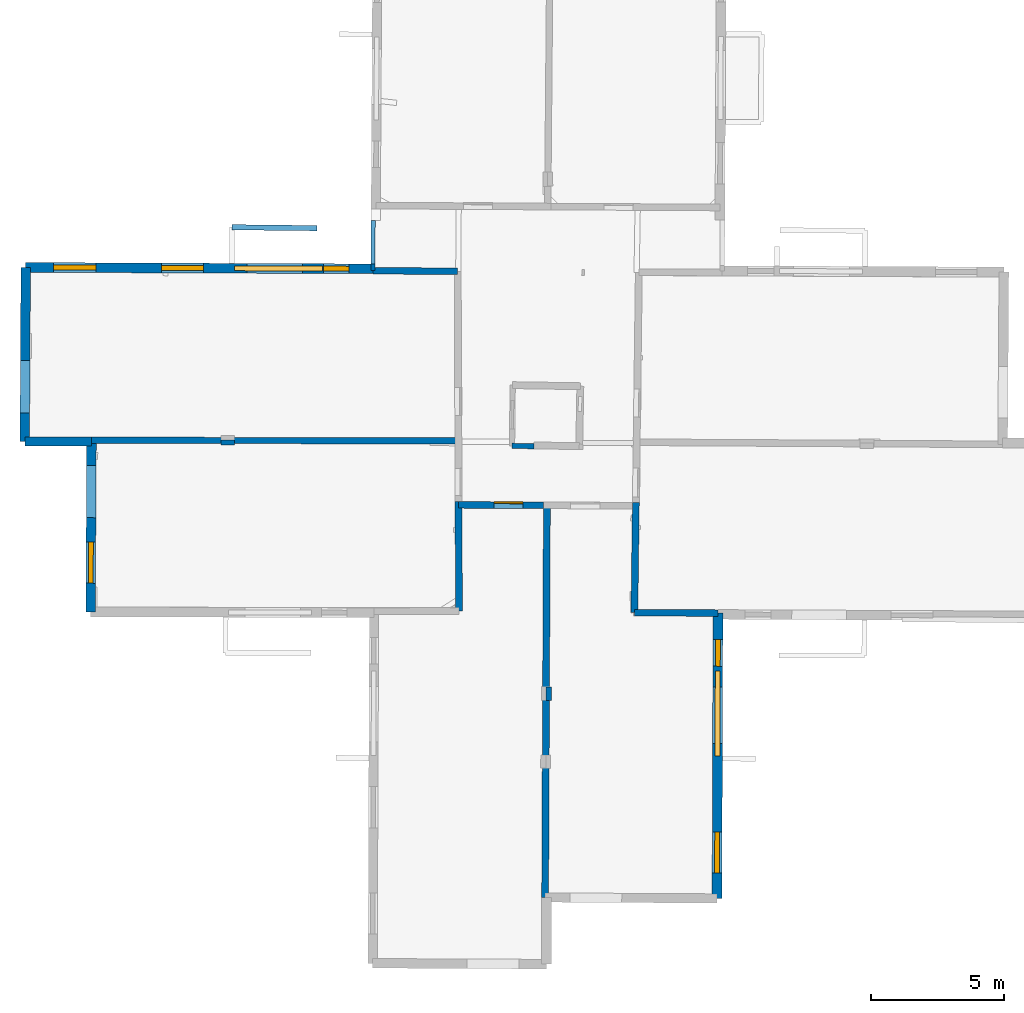
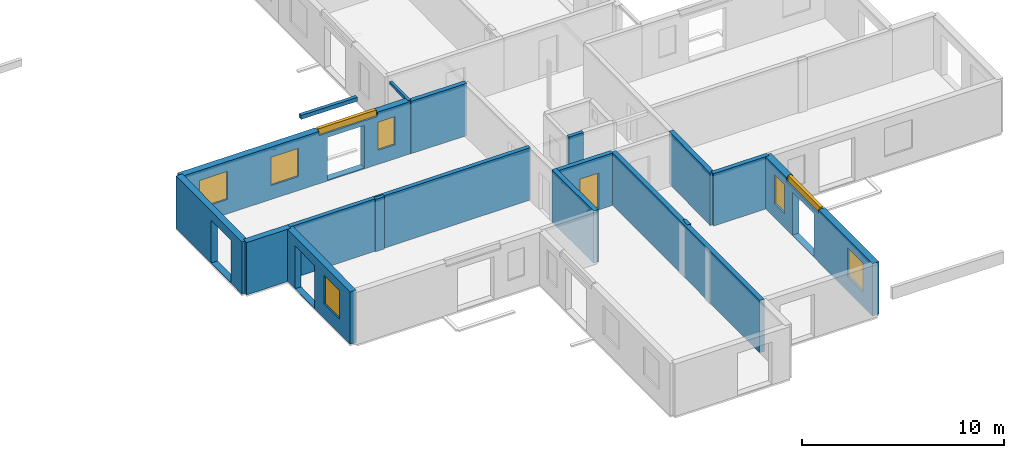
# One storey, part 4 of 17: 17 walls, 8 windows, 1 door, 14 openings.
"""IFC2X3 building model written with IfcOpenShell, lengths in metres."""

from ifc_helpers import new_model, entity, si_unit, converted_unit, derived_unit, direction, frame, frame_2d, origin, origin_2d_with_axis, place, context, subcontext, project, spatial, polyline, rectangle, outline, extrude, source, transform, mapped, material, layer, layer_set, layer_usage, type_object, type_shapes, element, fill, save


model = new_model("IFC2X3")

# Units and contexts
model_context = context("Model", 3, precision=1e-05, world=origin(), true_north=direction((0.0, 1.0)))
body_context = subcontext(model_context, "Body", "Model", "MODEL_VIEW")
ifc_project = project(units=[si_unit("LENGTHUNIT", "METRE"), si_unit("AREAUNIT", "SQUARE_METRE"), si_unit("VOLUMEUNIT", "CUBIC_METRE"), converted_unit("PLANEANGLEUNIT", "DEGREE", entity("IfcRatioMeasure", 0.0174532925199433), si_unit("PLANEANGLEUNIT", "RADIAN"), dimensions=[0, 0, 0, 0, 0, 0, 0]), si_unit("MASSUNIT", "GRAM", prefix="KILO"), derived_unit("MASSDENSITYUNIT", [(si_unit("MASSUNIT", "GRAM", prefix="KILO"), 1), (si_unit("LENGTHUNIT", "METRE"), -3)]), derived_unit("MOMENTOFINERTIAUNIT", [(si_unit("LENGTHUNIT", "METRE"), 4)]), si_unit("TIMEUNIT", "SECOND"), si_unit("FREQUENCYUNIT", "HERTZ"), si_unit("THERMODYNAMICTEMPERATUREUNIT", "DEGREE_CELSIUS"), derived_unit("THERMALTRANSMITTANCEUNIT", [(si_unit("MASSUNIT", "GRAM", prefix="KILO"), 1), (si_unit("THERMODYNAMICTEMPERATUREUNIT", "KELVIN"), -1), (si_unit("TIMEUNIT", "SECOND"), -3)]), derived_unit("VOLUMETRICFLOWRATEUNIT", [(si_unit("LENGTHUNIT", "METRE"), 3), (si_unit("TIMEUNIT", "SECOND"), -1)]), si_unit("ELECTRICCURRENTUNIT", "AMPERE"), si_unit("ELECTRICVOLTAGEUNIT", "VOLT"), si_unit("POWERUNIT", "WATT"), si_unit("FORCEUNIT", "NEWTON", prefix="KILO"), si_unit("ILLUMINANCEUNIT", "LUX"), si_unit("LUMINOUSFLUXUNIT", "LUMEN"), si_unit("LUMINOUSINTENSITYUNIT", "CANDELA"), derived_unit("USERDEFINED", [(si_unit("MASSUNIT", "GRAM", prefix="KILO"), -1), (si_unit("LENGTHUNIT", "METRE"), -2), (si_unit("TIMEUNIT", "SECOND"), 3), (si_unit("LUMINOUSFLUXUNIT", "LUMEN"), 1)]), derived_unit("LINEARVELOCITYUNIT", [(si_unit("LENGTHUNIT", "METRE"), 1), (si_unit("TIMEUNIT", "SECOND"), -1)]), si_unit("PRESSUREUNIT", "PASCAL"), derived_unit("USERDEFINED", [(si_unit("LENGTHUNIT", "METRE"), -2), (si_unit("MASSUNIT", "GRAM", prefix="KILO"), 1), (si_unit("TIMEUNIT", "SECOND"), -2)]), derived_unit("LINEARFORCEUNIT", [(si_unit("MASSUNIT", "GRAM", prefix="KILO"), 1), (si_unit("LENGTHUNIT", "METRE"), 1), (si_unit("TIMEUNIT", "SECOND"), -2), (si_unit("LENGTHUNIT", "METRE"), -1)]), derived_unit("PLANARFORCEUNIT", [(si_unit("MASSUNIT", "GRAM", prefix="KILO"), 1), (si_unit("LENGTHUNIT", "METRE"), 1), (si_unit("TIMEUNIT", "SECOND"), -2), (si_unit("LENGTHUNIT", "METRE"), -2)])], contexts=[model_context])

# Site, building, storey
placement_1 = place(None, origin())
site = spatial("IfcSite", under=ifc_project, at=placement_1, CompositionType="ELEMENT")
building = spatial("IfcBuilding", under=site, at=placement_1, CompositionType="ELEMENT")
storey_placement = place(placement_1, frame((0.0, 0.0, 5.56662893295288)))
storey = spatial("IfcBuildingStorey", under=building, at=storey_placement, Name="Level 3", CompositionType="ELEMENT", Elevation=5.56662893295288)

# Wall
ifc_material_1 = material(Name="Default wall")
ifc_layer_1 = layer(ifc_material_1, 0.25)
ifc_layer_set_1 = layer_set([ifc_layer_1], Name="wall_thickness_0.2500")
ifc_layer_usage_1 = layer_usage(ifc_layer_set_1, "AXIS2", "POSITIVE", -0.125)
wall_type_1 = type_object("IfcWallType", Name="wall_thickness_0.2500", PredefinedType="STANDARD", material=ifc_layer_set_1)
wall_1_placement = place(storey_placement, frame((-0.375098031248807, 25.8873114216496, 0.0), z_axis=(0.0, 0.0, 1.0), x_axis=(0.999973591431305, -0.00726749200057187, 0.0)))
element("IfcWallStandardCase", 1, at=wall_1_placement, inside=storey, type_object=wall_type_1, material=ifc_layer_usage_1, Name="Wall:0", ObjectType="Wall", context=body_context, shape_type="SweptSolid", body=[
    extrude(outline(polyline([(3.19820791514104, -0.125), (3.19820791514104, 0.125), (0.0, 0.125), (0.0, -0.125), (3.19820791514104, -0.125)])), origin(), (0.0, 0.0, 1.0), 3.16489877700806),
])

# Wall, opening, door
wall_2_placement = place(storey_placement, frame((2.85529090616385, 17.0561004002248, 0.0), z_axis=(0.0, 0.0, 1.0), x_axis=(0.99998830556549, -0.00483618984949817, 0.0)))
wall_2 = element("IfcWallStandardCase", 2, at=wall_2_placement, inside=storey, type_object=wall_type_1, material=ifc_layer_usage_1, Name="Wall:32", ObjectType="Wall", context=body_context, shape_type="SweptSolid", body=[
    extrude(outline(polyline([(3.20126987035994, -0.125), (3.20126987035994, 0.125), (0.0, 0.125), (0.0, -0.125), (3.20126987035994, -0.125)])), origin(), (0.0, 0.0, 1.0), 3.16489877700806),
])
opening_1_placement = place(wall_2_placement, frame((1.33784103138752, -0.125, 0.0543713569641113)))
opening_1 = element("IfcOpeningElement", 3, at=opening_1_placement, cuts=wall_2, Name="Opening : 1090 x 2180 : 25", ObjectType="Opening", context=body_context, shape_type="SweptSolid", body=[
    extrude(rectangle(XDim=1.09, YDim=2.18, at=frame_2d((1.09, 0.545), x_axis=(0.0, 1.0))), frame((0.0, 0.0, 0.0), z_axis=(0.0, 1.0, 0.0), x_axis=(0.0, 0.0, 1.0)), (0.0, 0.0, 1.0), 0.25),
])
ifc_material_2 = material(Name="Door Panel")
door_style = type_object("IfcDoorStyle", Name="Door : 1090 x 2180mm", ConstructionType="NOTDEFINED", OperationType="SINGLE_SWING_RIGHT", ParameterTakesPrecedence=False, Sizeable=False, material=ifc_material_2)
shared_shape_1 = source(origin(), body_context, "Body", "SweptSolid", [
    extrude(rectangle(XDim=0.0625, YDim=1.09, at=origin_2d_with_axis()), frame((0.545, 0.21875, 0.0), z_axis=(0.0, 0.0, 1.0), x_axis=(0.0, 1.0, 0.0)), (0.0, 0.0, 1.0), 2.18),
])
type_shapes(door_style, [shared_shape_1])
door_placement = place(opening_1_placement, origin())
door = element("IfcDoor", 4, at=door_placement, inside=storey, type_object=door_style, Name="Door : 1090 x 2180mm : 5", ObjectType="Door : 1090 x 2180mm", OverallHeight=2.18, OverallWidth=1.09, context=body_context, shape_type="MappedRepresentation", body=[
    mapped(shared_shape_1, transform((0.0, 0.0, 0.0), scale=1.0)),
])
fill(opening_1, door)

# Walls
wall_3_placement = place(storey_placement, frame((9.48690014869232, 12.99130469826, 0.0), z_axis=(0.0, 0.0, 1.0), x_axis=(0.999989966515221, -0.00447960588535751, 0.0)))
element("IfcWallStandardCase", 5, at=wall_3_placement, inside=storey, type_object=wall_type_1, material=ifc_layer_usage_1, Name="Wall:121", ObjectType="Wall", context=body_context, shape_type="SweptSolid", body=[
    extrude(outline(polyline([(3.14995683697757, -0.125), (3.14995683697757, 0.125), (0.0, 0.125), (0.0, -0.125), (3.14995683697757, -0.125)])), origin(), (0.0, 0.0, 1.0), 3.16489877700806),
])
ifc_layer_2 = layer(ifc_material_1, 0.349999994039536)
ifc_layer_set_2 = layer_set([ifc_layer_2], Name="wall_thickness_0.3500")
ifc_layer_usage_2 = layer_usage(ifc_layer_set_2, "AXIS2", "POSITIVE", -0.174999997019768)
wall_type_2 = type_object("IfcWallType", Name="wall_thickness_0.3500", PredefinedType="STANDARD", material=ifc_layer_set_2)
wall_4_placement = place(storey_placement, frame((-13.5018670157052, 19.4465529035033, 0.0), z_axis=(0.0, 0.0, 1.0), x_axis=(0.999999239159448, -0.00123356415550163, 0.0)))
element("IfcWallStandardCase", 6, at=wall_4_placement, inside=storey, type_object=wall_type_2, material=ifc_layer_usage_2, Name="Wall:41", ObjectType="Wall", context=body_context, shape_type="SweptSolid", body=[
    extrude(outline(polyline([(2.51722908806153, -0.174999997019768), (2.51722908806153, 0.174999997019768), (0.0, 0.174999997019768), (0.0, -0.174999997019768), (2.51722908806153, -0.174999997019768)])), origin(), (0.0, 0.0, 1.0), 3.16489877700806),
])
ifc_layer_3 = layer(ifc_material_1, 0.2)
ifc_layer_set_3 = layer_set([ifc_layer_3], Name="wall_thickness_0.2000")
ifc_layer_usage_3 = layer_usage(ifc_layer_set_3, "AXIS2", "POSITIVE", -0.1)
wall_type_3 = type_object("IfcWallType", Name="wall_thickness_0.2000", PredefinedType="STANDARD", material=ifc_layer_set_3)
wall_5_placement = place(storey_placement, frame((-6.10965351913021, 19.4128128129455, 0.0), z_axis=(0.0, 0.0, 1.0), x_axis=(0.999961930718364, -0.00872565837070076, 0.0)))
element("IfcWallStandardCase", 7, at=wall_5_placement, inside=storey, type_object=wall_type_3, material=ifc_layer_usage_3, Name="Wall:31", ObjectType="Wall", context=body_context, shape_type="SweptSolid", body=[
    extrude(outline(polyline([(0.514999921839177, -0.1), (0.514999921839177, 0.1), (0.0, 0.1), (0.0, -0.1), (0.514999921839177, -0.1)])), origin(), (0.0, 0.0, 1.0), 3.16489877700806),
])
wall_6_placement = place(storey_placement, frame((4.8713702368692, 19.2825277990981, 0.0), z_axis=(0.0, 0.0, 1.0), x_axis=(0.999888119327468, -0.01495823611856, 0.0)))
element("IfcWallStandardCase", 8, at=wall_6_placement, inside=storey, type_object=wall_type_3, material=ifc_layer_usage_3, Name="Wall:84", ObjectType="Wall", context=body_context, shape_type="SweptSolid", body=[
    extrude(outline(polyline([(0.826020150064914, -0.1), (0.826020150064914, 0.1), (0.0, 0.1), (0.0, -0.1), (0.826020150064914, -0.1)])), origin(), (0.0, 0.0, 1.0), 3.16489877700806),
])
wall_7_placement = place(storey_placement, frame((6.25925555797266, 10.1927285527947, 0.0), z_axis=(0.0, 0.0, 1.0), x_axis=(-0.0139859666405672, -0.999902191585321, 0.0)))
element("IfcWallStandardCase", 9, at=wall_7_placement, inside=storey, type_object=wall_type_3, material=ifc_layer_usage_3, Name="Wall:111", ObjectType="Wall", context=body_context, shape_type="SweptSolid", body=[
    extrude(outline(polyline([(0.504999916617722, -0.1), (0.504999916617722, 0.1), (0.0, 0.1), (0.0, -0.1), (0.504999916617722, -0.1)])), origin(), (0.0, 0.0, 1.0), 3.16489877700806),
])
placement_2 = place(placement_1, frame((0.0, 0.0, 8.49600028991699)))
wall_8_placement = place(placement_2, frame((-5.68529039419917, 27.5262788025759, 0.0), z_axis=(0.0, 0.0, 1.0), x_axis=(0.99994011716645, -0.0109435863018161, 0.0)))
element("IfcWallStandardCase", 10, at=wall_8_placement, inside=storey, type_object=wall_type_3, material=ifc_layer_usage_3, Name="Wall:115", ObjectType="Wall", context=body_context, shape_type="SweptSolid", body=[
    extrude(outline(polyline([(3.20204073103676, -0.1), (3.20204073103676, 0.1), (0.0, 0.1), (0.0, -0.1), (3.20204073103676, -0.1)])), origin(), (0.0, 0.0, 1.0), 0.235527420043946),
])
ifc_layer_4 = layer(ifc_material_1, 0.239999994635582)
ifc_layer_set_4 = layer_set([ifc_layer_4], Name="wall_thickness_0.2400")
ifc_layer_usage_4 = layer_usage(ifc_layer_set_4, "AXIS2", "POSITIVE", -0.119999997317791)
wall_type_4 = type_object("IfcWallType", Name="wall_thickness_0.2400", PredefinedType="STANDARD", material=ifc_layer_set_4)
wall_9_placement = place(storey_placement, frame((-10.9843472895199, 19.4933862629135, 0.0), z_axis=(0.0, 0.0, 1.0), x_axis=(0.99999902136168, -0.00139902669093258, 0.0)))
element("IfcWallStandardCase", 11, at=wall_9_placement, inside=storey, type_object=wall_type_4, material=ifc_layer_usage_4, Name="Wall:78", ObjectType="Wall", context=body_context, shape_type="SweptSolid", body=[
    extrude(outline(polyline([(13.7629142982305, -0.119999997317791), (13.7629142982305, 0.119999997317791), (0.0, 0.119999997317791), (0.0, -0.119999997317791), (13.7629142982305, -0.119999997317791)])), origin(), (0.0, 0.0, 1.0), 3.16489877700806),
])
ifc_layer_5 = layer(ifc_material_1, 0.259999990463257)
ifc_layer_set_5 = layer_set([ifc_layer_5], Name="wall_thickness_0.2600")
ifc_layer_usage_5 = layer_usage(ifc_layer_set_5, "AXIS2", "POSITIVE", -0.129999995231628)
wall_type_5 = type_object("IfcWallType", Name="wall_thickness_0.2600", PredefinedType="STANDARD", material=ifc_layer_set_5)
wall_10_placement = place(storey_placement, frame((6.18652200434663, 17.0399905416038, 0.0), z_axis=(0.0, 0.0, 1.0), x_axis=(-0.00449614642653608, -0.999989892282573, 0.0)))
element("IfcWallStandardCase", 12, at=wall_10_placement, inside=storey, type_object=wall_type_5, material=ifc_layer_usage_5, Name="Wall:49", ObjectType="Wall", context=body_context, shape_type="SweptSolid", body=[
    extrude(outline(polyline([(14.7886822137382, -0.129999995231628), (14.7886822137382, 0.129999995231628), (0.0, 0.129999995231628), (0.0, -0.129999995231628), (14.7886822137382, -0.129999995231628)])), origin(), (0.0, 0.0, 1.0), 3.16489877700806),
])
wall_11_placement = place(storey_placement, frame((9.54088629131303, 17.1487579854942, 0.0), z_axis=(0.0, 0.0, 1.0), x_axis=(-0.0129843900336636, -0.999915699254419, 0.0)))
element("IfcWallStandardCase", 13, at=wall_11_placement, inside=storey, type_object=wall_type_5, material=ifc_layer_usage_5, Name="Wall:97", ObjectType="Wall", context=body_context, shape_type="SweptSolid", body=[
    extrude(outline(polyline([(4.15780404296811, -0.129999995231628), (4.15780404296811, 0.129999995231628), (0.0, 0.129999995231628), (0.0, -0.129999995231628), (4.15780404296811, -0.129999995231628)])), origin(), (0.0, 0.0, 1.0), 3.16489877700806),
])
wall_12_placement = place(storey_placement, frame((2.85483316387251, 17.1810957364679, 0.0), z_axis=(0.0, 0.0, 1.0), x_axis=(0.00366324595240334, -0.999993290292036, 0.0)))
element("IfcWallStandardCase", 14, at=wall_12_placement, inside=storey, type_object=wall_type_5, material=ifc_layer_usage_5, Name="Wall:118", ObjectType="Wall", context=body_context, shape_type="SweptSolid", body=[
    extrude(outline(polyline([(4.12664893494711, -0.129999995231628), (4.12664893494711, 0.129999995231628), (0.0, 0.129999995231628), (0.0, -0.129999995231628), (4.12664893494711, -0.129999995231628)])), origin(), (0.0, 0.0, 1.0), 3.16489877700806),
])

# Wall, opening
ifc_layer_6 = layer(ifc_material_1, 0.159999996423721)
ifc_layer_set_6 = layer_set([ifc_layer_6], Name="wall_thickness_0.1600")
ifc_layer_usage_6 = layer_usage(ifc_layer_set_6, "AXIS2", "POSITIVE", -0.0799999982118607)
wall_type_6 = type_object("IfcWallType", Name="wall_thickness_0.1600", PredefinedType="STANDARD", material=ifc_layer_set_6)
wall_13_placement = place(storey_placement, frame((-0.364432019139794, 27.7737176115581, 0.0), z_axis=(0.0, 0.0, 1.0), x_axis=(-0.0056538909411411, -0.999984016630879, 0.0)))
wall_13 = element("IfcWallStandardCase", 15, at=wall_13_placement, inside=storey, type_object=wall_type_6, material=ifc_layer_usage_6, Name="Wall:14", ObjectType="Wall", context=body_context, shape_type="SweptSolid", body=[
    extrude(outline(polyline([(1.88643800380779, -0.0799999982118607), (1.88643800380779, 0.0799999982118607), (0.0, 0.0799999982118607), (0.0, -0.0799999982118607), (1.88643800380779, -0.0799999982118607)])), origin(), (0.0, 0.0, 1.0), 3.16489877700806),
])
opening_2_placement = place(wall_13_placement, frame((-0.332795693054084, -0.0799999982118607, 0.00537109375)))
element("IfcOpeningElement", 16, at=opening_2_placement, cuts=wall_13, Name="Opening : 1960 x 3005 : 17", ObjectType="Opening", context=body_context, shape_type="SweptSolid", body=[
    extrude(rectangle(XDim=1.96, YDim=3.005, at=frame_2d((1.5025, 0.98), x_axis=(0.0, 1.0))), frame((0.0, 0.0, 0.0), z_axis=(0.0, 1.0, 0.0), x_axis=(0.0, 0.0, 1.0)), (0.0, 0.0, 1.0), 0.159999996423721),
])

# Wall, openings, windows
ifc_layer_7 = layer(ifc_material_1, 0.370000004768372)
ifc_layer_set_7 = layer_set([ifc_layer_7], Name="wall_thickness_0.3700")
ifc_layer_usage_7 = layer_usage(ifc_layer_set_7, "AXIS2", "POSITIVE", -0.185000002384186)
wall_type_7 = type_object("IfcWallType", Name="wall_thickness_0.3700", PredefinedType="STANDARD", material=ifc_layer_set_7)
wall_14_placement = place(storey_placement, frame((12.6368260276336, 12.9771953929601, 0.0), z_axis=(0.0, 0.0, 1.0), x_axis=(-0.0032921088167859, -0.999994580995086, 0.0)))
wall_14 = element("IfcWallStandardCase", 17, at=wall_14_placement, inside=storey, type_object=wall_type_7, material=ifc_layer_usage_7, Name="Wall:38", ObjectType="Wall", context=body_context, shape_type="SweptSolid", body=[
    extrude(outline(polyline([(10.7612158277462, -0.185000002384186), (10.7612158277462, 0.185000002384186), (0.0, 0.185000002384186), (0.0, -0.185000002384186), (10.7612158277462, -0.185000002384186)])), origin(), (0.0, 0.0, 1.0), 3.16489877700806),
])
opening_3_placement = place(wall_14_placement, frame((2.79032026854389, -0.185000002384186, 0.0513710975646973)))
element("IfcOpeningElement", 18, at=opening_3_placement, cuts=wall_14, Name="Opening : 2125 x 2580 : 27", ObjectType="Opening", context=body_context, shape_type="SweptSolid", body=[
    extrude(rectangle(XDim=2.125, YDim=2.58, at=frame_2d((1.29, 1.0625), x_axis=(0.0, 1.0))), frame((0.0, 0.0, 0.0), z_axis=(0.0, 1.0, 0.0), x_axis=(0.0, 0.0, 1.0)), (0.0, 0.0, 1.0), 0.370000004768372),
])
opening_4_placement = place(wall_14_placement, frame((8.25509159047681, -0.185000002384186, 0.875370979309082)))
opening_4 = element("IfcOpeningElement", 19, at=opening_4_placement, cuts=wall_14, Name="Opening : 1555 x 1735 : 28", ObjectType="Opening", context=body_context, shape_type="SweptSolid", body=[
    extrude(rectangle(XDim=1.555, YDim=1.735, at=frame_2d((0.8675, 0.7775), x_axis=(0.0, 1.0))), frame((0.0, 0.0, 0.0), z_axis=(0.0, 1.0, 0.0), x_axis=(0.0, 0.0, 1.0)), (0.0, 0.0, 1.0), 0.370000004768372),
])
opening_5_placement = place(wall_14_placement, frame((1.00009030641048, -0.185000002384186, 0.870370864868164)))
opening_5 = element("IfcOpeningElement", 20, at=opening_5_placement, cuts=wall_14, Name="Opening : 1005 x 1735 : 29", ObjectType="Opening", context=body_context, shape_type="SweptSolid", body=[
    extrude(rectangle(XDim=1.005, YDim=1.735, at=frame_2d((0.8675, 0.5025), x_axis=(0.0, 1.0))), frame((0.0, 0.0, 0.0), z_axis=(0.0, 1.0, 0.0), x_axis=(0.0, 0.0, 1.0)), (0.0, 0.0, 1.0), 0.370000004768372),
])
opening_6_placement = place(wall_14_placement, frame((2.18509047292211, -0.185000002384186, 2.91037034988403)))
opening_6 = element("IfcOpeningElement", 21, at=opening_6_placement, cuts=wall_14, Name="Opening : 3200 x 345 : 30", ObjectType="Opening", context=body_context, shape_type="SweptSolid", body=[
    extrude(rectangle(XDim=3.2, YDim=0.345, at=frame_2d((0.1725, 1.6), x_axis=(0.0, 1.0))), frame((0.0, 0.0, 0.0), z_axis=(0.0, 1.0, 0.0), x_axis=(0.0, 0.0, 1.0)), (0.0, 0.0, 1.0), 0.370000004768372),
])
ifc_material_3 = material(Name="Window Default")
window_style_1 = type_object("IfcWindowStyle", Name="Window : 1555 x 1735mm", ConstructionType="NOTDEFINED", OperationType="NOTDEFINED", ParameterTakesPrecedence=False, Sizeable=False, material=ifc_material_3)
shared_shape_2 = source(origin(), body_context, "Body", "SweptSolid", [
    extrude(rectangle(XDim=0.185000002384186, YDim=1.555, at=origin_2d_with_axis()), frame((0.7775, 0.185000002384186, 0.0), z_axis=(0.0, 0.0, 1.0), x_axis=(0.0, 1.0, 0.0)), (0.0, 0.0, 1.0), 1.735),
])
type_shapes(window_style_1, [shared_shape_2])
window_1_placement = place(opening_4_placement, origin())
window_1 = element("IfcWindow", 22, at=window_1_placement, inside=storey, type_object=window_style_1, Name="Window : 1555 x 1735mm : 14", ObjectType="Window : 1555 x 1735mm", OverallHeight=1.735, OverallWidth=1.555, context=body_context, shape_type="MappedRepresentation", body=[
    mapped(shared_shape_2, transform((0.0, 0.0, 0.0), scale=1.0)),
])
fill(opening_4, window_1)
window_style_2 = type_object("IfcWindowStyle", Name="Window : 1005 x 1735mm", ConstructionType="NOTDEFINED", OperationType="NOTDEFINED", ParameterTakesPrecedence=False, Sizeable=False, material=ifc_material_3)
shared_shape_3 = source(origin(), body_context, "Body", "SweptSolid", [
    extrude(rectangle(XDim=0.185000002384186, YDim=1.005, at=origin_2d_with_axis()), frame((0.5025, 0.185000002384186, 0.0), z_axis=(0.0, 0.0, 1.0), x_axis=(0.0, 1.0, 0.0)), (0.0, 0.0, 1.0), 1.735),
])
type_shapes(window_style_2, [shared_shape_3])
window_2_placement = place(opening_5_placement, origin())
window_2 = element("IfcWindow", 23, at=window_2_placement, inside=storey, type_object=window_style_2, Name="Window : 1005 x 1735mm : 15", ObjectType="Window : 1005 x 1735mm", OverallHeight=1.735, OverallWidth=1.005, context=body_context, shape_type="MappedRepresentation", body=[
    mapped(shared_shape_3, transform((0.0, 0.0, 0.0), scale=1.0)),
])
fill(opening_5, window_2)
window_style_3 = type_object("IfcWindowStyle", Name="Window : 3200 x 345mm", ConstructionType="NOTDEFINED", OperationType="NOTDEFINED", ParameterTakesPrecedence=False, Sizeable=False, material=ifc_material_3)
shared_shape_4 = source(origin(), body_context, "Body", "SweptSolid", [
    extrude(rectangle(XDim=0.185000002384186, YDim=3.2, at=origin_2d_with_axis()), frame((1.6, 0.185000002384186, 0.0), z_axis=(0.0, 0.0, 1.0), x_axis=(0.0, 1.0, 0.0)), (0.0, 0.0, 1.0), 0.345),
])
type_shapes(window_style_3, [shared_shape_4])
window_3_placement = place(opening_6_placement, origin())
window_3 = element("IfcWindow", 24, at=window_3_placement, inside=storey, type_object=window_style_3, Name="Window : 3200 x 345mm : 16", ObjectType="Window : 3200 x 345mm", OverallHeight=0.345, OverallWidth=3.2, context=body_context, shape_type="MappedRepresentation", body=[
    mapped(shared_shape_4, transform((0.0, 0.0, 0.0), scale=1.0)),
])
fill(opening_6, window_3)

wall_15_placement = place(storey_placement, frame((-13.4663784100946, 26.0114984459389, 0.0), z_axis=(0.0, 0.0, 1.0), x_axis=(0.999991972833218, -0.0040067778985801, 0.0)))
wall_15 = element("IfcWallStandardCase", 25, at=wall_15_placement, inside=storey, type_object=wall_type_7, material=ifc_layer_usage_7, Name="Wall:122", ObjectType="Wall", context=body_context, shape_type="SweptSolid", body=[
    extrude(outline(polyline([(13.0917918156128, -0.185000002384186), (13.0917918156128, 0.185000002384186), (0.0, 0.185000002384186), (0.0, -0.185000002384186), (13.0917918156128, -0.185000002384186)])), origin(), (0.0, 0.0, 1.0), 3.16489877700806),
])
opening_7_placement = place(wall_15_placement, frame((8.33558759991493, -0.185000002384186, 0.0593714714050293)))
element("IfcOpeningElement", 26, at=opening_7_placement, cuts=wall_15, Name="Opening : 2110 x 2570 : 110", ObjectType="Opening", context=body_context, shape_type="SweptSolid", body=[
    extrude(rectangle(XDim=2.11, YDim=2.57, at=frame_2d((1.285, 1.055), x_axis=(0.0, 1.0))), frame((0.0, 0.0, 0.0), z_axis=(0.0, 1.0, 0.0), x_axis=(0.0, 0.0, 1.0)), (0.0, 0.0, 1.0), 0.370000004768372),
])
opening_8_placement = place(wall_15_placement, frame((1.05221252453655, -0.185000002384186, 0.870370864868164)))
opening_8 = element("IfcOpeningElement", 27, at=opening_8_placement, cuts=wall_15, Name="Opening : 1595 x 1700 : 111", ObjectType="Opening", context=body_context, shape_type="SweptSolid", body=[
    extrude(rectangle(XDim=1.595, YDim=1.7, at=frame_2d((0.85, 0.7975), x_axis=(0.0, 1.0))), frame((0.0, 0.0, 0.0), z_axis=(0.0, 1.0, 0.0), x_axis=(0.0, 0.0, 1.0)), (0.0, 0.0, 1.0), 0.370000004768372),
])
opening_9_placement = place(wall_15_placement, frame((5.11721230761429, -0.185000002384186, 0.845370769500732)))
opening_9 = element("IfcOpeningElement", 28, at=opening_9_placement, cuts=wall_15, Name="Opening : 1585 x 1710 : 112", ObjectType="Opening", context=body_context, shape_type="SweptSolid", body=[
    extrude(rectangle(XDim=1.585, YDim=1.71, at=frame_2d((0.855, 0.7925), x_axis=(0.0, 1.0))), frame((0.0, 0.0, 0.0), z_axis=(0.0, 1.0, 0.0), x_axis=(0.0, 0.0, 1.0)), (0.0, 0.0, 1.0), 0.370000004768372),
])
opening_10_placement = place(wall_15_placement, frame((7.8743107191467, -0.185000002384186, 2.90537118911743)))
opening_10 = element("IfcOpeningElement", 29, at=opening_10_placement, cuts=wall_15, Name="Opening : 3310 x 350 : 113", ObjectType="Opening", context=body_context, shape_type="SweptSolid", body=[
    extrude(rectangle(XDim=3.31, YDim=0.35, at=frame_2d((0.175, 1.655), x_axis=(0.0, 1.0))), frame((0.0, 0.0, 0.0), z_axis=(0.0, 1.0, 0.0), x_axis=(0.0, 0.0, 1.0)), (0.0, 0.0, 1.0), 0.370000004768372),
])
opening_11_placement = place(wall_15_placement, frame((11.2272123705129, -0.185000002384186, 0.855370998382568)))
opening_11 = element("IfcOpeningElement", 30, at=opening_11_placement, cuts=wall_15, Name="Opening : 960 x 1700 : 114", ObjectType="Opening", context=body_context, shape_type="SweptSolid", body=[
    extrude(rectangle(XDim=0.96, YDim=1.7, at=frame_2d((0.85, 0.48), x_axis=(0.0, 1.0))), frame((0.0, 0.0, 0.0), z_axis=(0.0, 1.0, 0.0), x_axis=(0.0, 0.0, 1.0)), (0.0, 0.0, 1.0), 0.370000004768372),
])
window_style_4 = type_object("IfcWindowStyle", Name="Window : 1595 x 1700mm", ConstructionType="NOTDEFINED", OperationType="NOTDEFINED", ParameterTakesPrecedence=False, Sizeable=False, material=ifc_material_3)
shared_shape_5 = source(origin(), body_context, "Body", "SweptSolid", [
    extrude(rectangle(XDim=0.185000002384186, YDim=1.595, at=origin_2d_with_axis()), frame((0.7975, 0.185000002384186, 0.0), z_axis=(0.0, 0.0, 1.0), x_axis=(0.0, 1.0, 0.0)), (0.0, 0.0, 1.0), 1.7),
])
type_shapes(window_style_4, [shared_shape_5])
window_4_placement = place(opening_8_placement, origin())
window_4 = element("IfcWindow", 31, at=window_4_placement, inside=storey, type_object=window_style_4, Name="Window : 1595 x 1700mm : 65", ObjectType="Window : 1595 x 1700mm", OverallHeight=1.7, OverallWidth=1.595, context=body_context, shape_type="MappedRepresentation", body=[
    mapped(shared_shape_5, transform((0.0, 0.0, 0.0), scale=1.0)),
])
fill(opening_8, window_4)
window_style_5 = type_object("IfcWindowStyle", Name="Window : 1585 x 1710mm", ConstructionType="NOTDEFINED", OperationType="NOTDEFINED", ParameterTakesPrecedence=False, Sizeable=False, material=ifc_material_3)
shared_shape_6 = source(origin(), body_context, "Body", "SweptSolid", [
    extrude(rectangle(XDim=0.185000002384186, YDim=1.585, at=origin_2d_with_axis()), frame((0.7925, 0.185000002384186, 0.0), z_axis=(0.0, 0.0, 1.0), x_axis=(0.0, 1.0, 0.0)), (0.0, 0.0, 1.0), 1.71),
])
type_shapes(window_style_5, [shared_shape_6])
window_5_placement = place(opening_9_placement, origin())
window_5 = element("IfcWindow", 32, at=window_5_placement, inside=storey, type_object=window_style_5, Name="Window : 1585 x 1710mm : 66", ObjectType="Window : 1585 x 1710mm", OverallHeight=1.71, OverallWidth=1.585, context=body_context, shape_type="MappedRepresentation", body=[
    mapped(shared_shape_6, transform((0.0, 0.0, 0.0), scale=1.0)),
])
fill(opening_9, window_5)
window_style_6 = type_object("IfcWindowStyle", Name="Window : 3310 x 350mm", ConstructionType="NOTDEFINED", OperationType="NOTDEFINED", ParameterTakesPrecedence=False, Sizeable=False, material=ifc_material_3)
shared_shape_7 = source(origin(), body_context, "Body", "SweptSolid", [
    extrude(rectangle(XDim=0.185000002384186, YDim=3.31, at=origin_2d_with_axis()), frame((1.655, 0.185000002384186, 0.0), z_axis=(0.0, 0.0, 1.0), x_axis=(0.0, 1.0, 0.0)), (0.0, 0.0, 1.0), 0.35),
])
type_shapes(window_style_6, [shared_shape_7])
window_6_placement = place(opening_10_placement, origin())
window_6 = element("IfcWindow", 33, at=window_6_placement, inside=storey, type_object=window_style_6, Name="Window : 3310 x 350mm : 67", ObjectType="Window : 3310 x 350mm", OverallHeight=0.35, OverallWidth=3.31, context=body_context, shape_type="MappedRepresentation", body=[
    mapped(shared_shape_7, transform((0.0, 0.0, 0.0), scale=1.0)),
])
fill(opening_10, window_6)
window_style_7 = type_object("IfcWindowStyle", Name="Window : 960 x 1700mm", ConstructionType="NOTDEFINED", OperationType="NOTDEFINED", ParameterTakesPrecedence=False, Sizeable=False, material=ifc_material_3)
shared_shape_8 = source(origin(), body_context, "Body", "SweptSolid", [
    extrude(rectangle(XDim=0.185000002384186, YDim=0.96, at=origin_2d_with_axis()), frame((0.48, 0.185000002384186, 0.0), z_axis=(0.0, 0.0, 1.0), x_axis=(0.0, 1.0, 0.0)), (0.0, 0.0, 1.0), 1.7),
])
type_shapes(window_style_7, [shared_shape_8])
window_7_placement = place(opening_11_placement, origin())
window_7 = element("IfcWindow", 34, at=window_7_placement, inside=storey, type_object=window_style_7, Name="Window : 960 x 1700mm : 68", ObjectType="Window : 960 x 1700mm", OverallHeight=1.7, OverallWidth=0.96, context=body_context, shape_type="MappedRepresentation", body=[
    mapped(shared_shape_8, transform((0.0, 0.0, 0.0), scale=1.0)),
])
fill(opening_11, window_7)

# Wall, openings, window
ifc_layer_8 = layer(ifc_material_1, 0.360000014305115)
ifc_layer_set_8 = layer_set([ifc_layer_8], Name="wall_thickness_0.3600")
ifc_layer_usage_8 = layer_usage(ifc_layer_set_8, "AXIS2", "POSITIVE", -0.180000007152557)
wall_type_8 = type_object("IfcWallType", Name="wall_thickness_0.3600", PredefinedType="STANDARD", material=ifc_layer_set_8)
wall_16_placement = place(storey_placement, frame((-10.984640664437, 19.443450176519, 0.0), z_axis=(0.0, 0.0, 1.0), x_axis=(-0.00587459154771503, -0.999982744438197, 0.0)))
wall_16 = element("IfcWallStandardCase", 35, at=wall_16_placement, inside=storey, type_object=wall_type_8, material=ifc_layer_usage_8, Name="Wall:69", ObjectType="Wall", context=body_context, shape_type="SweptSolid", body=[
    extrude(outline(polyline([(6.4221241001352, -0.180000007152557), (6.4221241001352, 0.180000007152557), (0.0, 0.180000007152557), (0.0, -0.180000007152557), (6.4221241001352, -0.180000007152557)])), origin(), (0.0, 0.0, 1.0), 3.16489877700806),
])
opening_12_placement = place(wall_16_placement, frame((0.896034450293231, -0.180000007152557, 0.00537109375)))
element("IfcOpeningElement", 36, at=opening_12_placement, cuts=wall_16, Name="Opening : 1975 x 2595 : 67", ObjectType="Opening", context=body_context, shape_type="SweptSolid", body=[
    extrude(rectangle(XDim=1.975, YDim=2.595, at=frame_2d((1.2975, 0.9875), x_axis=(0.0, 1.0))), frame((0.0, 0.0, 0.0), z_axis=(0.0, 1.0, 0.0), x_axis=(0.0, 0.0, 1.0)), (0.0, 0.0, 1.0), 0.360000014305115),
])
opening_13_placement = place(wall_16_placement, frame((3.79103336411188, -0.180000007152557, 0.875370979309082)))
opening_13 = element("IfcOpeningElement", 37, at=opening_13_placement, cuts=wall_16, Name="Opening : 1550 x 1725 : 68", ObjectType="Opening", context=body_context, shape_type="SweptSolid", body=[
    extrude(rectangle(XDim=1.55, YDim=1.725, at=frame_2d((0.8625, 0.775), x_axis=(0.0, 1.0))), frame((0.0, 0.0, 0.0), z_axis=(0.0, 1.0, 0.0), x_axis=(0.0, 0.0, 1.0)), (0.0, 0.0, 1.0), 0.360000014305115),
])
window_style_8 = type_object("IfcWindowStyle", Name="Window : 1550 x 1725mm", ConstructionType="NOTDEFINED", OperationType="NOTDEFINED", ParameterTakesPrecedence=False, Sizeable=False, material=ifc_material_3)
shared_shape_9 = source(origin(), body_context, "Body", "SweptSolid", [
    extrude(rectangle(XDim=0.180000007152557, YDim=1.55, at=origin_2d_with_axis()), frame((0.775, 0.180000007152557, 0.0), z_axis=(0.0, 0.0, 1.0), x_axis=(0.0, 1.0, 0.0)), (0.0, 0.0, 1.0), 1.725),
])
type_shapes(window_style_8, [shared_shape_9])
window_8_placement = place(opening_13_placement, origin())
window_8 = element("IfcWindow", 38, at=window_8_placement, inside=storey, type_object=window_style_8, Name="Window : 1550 x 1725mm : 42", ObjectType="Window : 1550 x 1725mm", OverallHeight=1.725, OverallWidth=1.55, context=body_context, shape_type="MappedRepresentation", body=[
    mapped(shared_shape_9, transform((0.0, 0.0, 0.0), scale=1.0)),
])
fill(opening_13, window_8)

# Wall, opening
wall_17_placement = place(storey_placement, frame((-13.4663754181112, 26.0114971830417, 0.0), z_axis=(0.0, 0.0, 1.0), x_axis=(-0.00540591219486789, -0.999985387949915, 0.0)))
wall_17 = element("IfcWallStandardCase", 39, at=wall_17_placement, inside=storey, type_object=wall_type_8, material=ifc_layer_usage_8, Name="Wall:71", ObjectType="Wall", context=body_context, shape_type="SweptSolid", body=[
    extrude(outline(polyline([(6.56504114965736, -0.180000007152557), (6.56504114965736, 0.180000007152557), (0.0, 0.180000007152557), (0.0, -0.180000007152557), (6.56504114965736, -0.180000007152557)])), origin(), (0.0, 0.0, 1.0), 3.16489877700806),
])
opening_14_placement = place(wall_17_placement, frame((3.50695966132002, -0.180000007152557, 0.0363712310791016)))
element("IfcOpeningElement", 40, at=opening_14_placement, cuts=wall_17, Name="Opening : 1990 x 2575 : 69", ObjectType="Opening", context=body_context, shape_type="SweptSolid", body=[
    extrude(rectangle(XDim=1.99, YDim=2.575, at=frame_2d((1.2875, 0.995), x_axis=(0.0, 1.0))), frame((0.0, 0.0, 0.0), z_axis=(0.0, 1.0, 0.0), x_axis=(0.0, 0.0, 1.0)), (0.0, 0.0, 1.0), 0.360000014305115),
])

save(model, "model.ifc")
